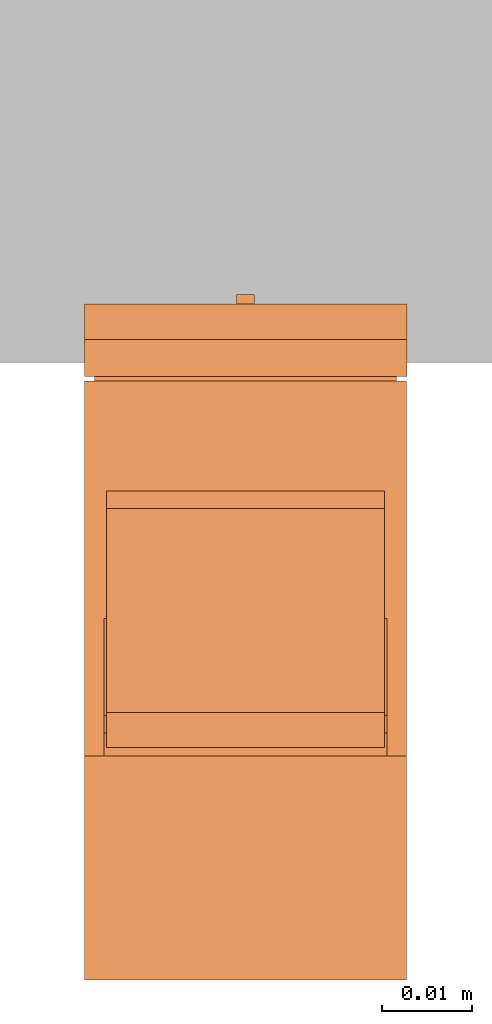
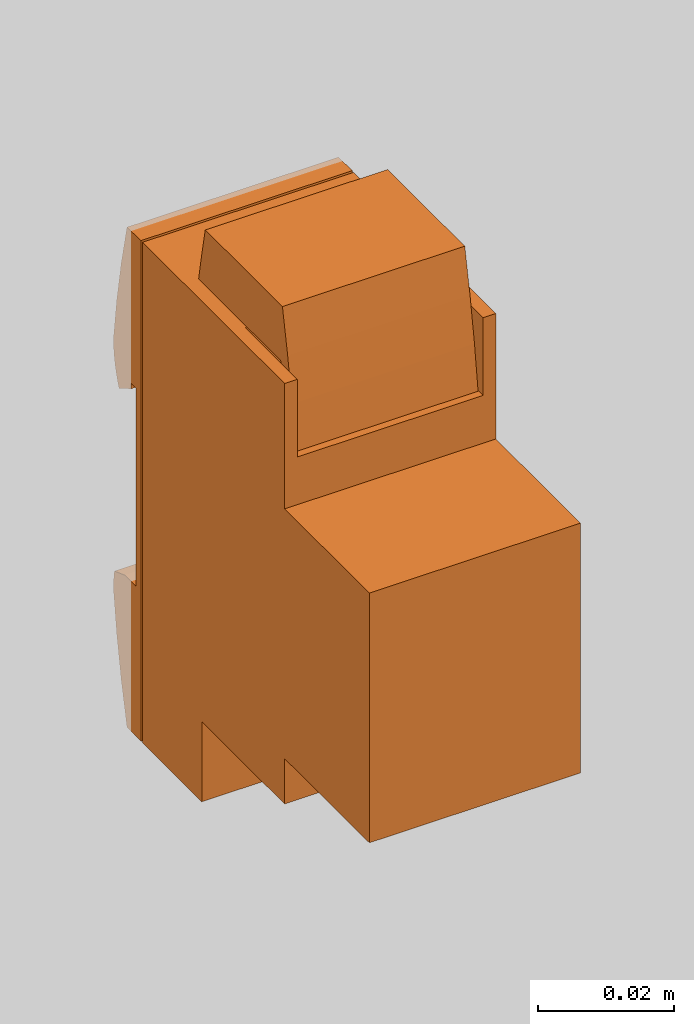
# One storey, part 2 of 2: 1 proxy.
"""IFC2X3 building model written with IfcOpenShell, lengths in metres."""

from ifc_helpers import new_model, entity, si_unit, converted_unit, derived_unit, direction, frame, frame_2d, origin, origin_2d_with_axis, place, context, subcontext, project, spatial, polyline, circle_curve, parameter, trimmed, segment, composite_curve, rectangle, circle, outline, extrude, source, transform, mapped, type_object, type_shapes, element, save


model = new_model("IFC2X3")

# Units and contexts
model_context = context("Model", 3, precision=1e-05, world=origin(), true_north=direction((6.12303176911189e-17, 1.0)))
body_context = subcontext(model_context, "Body", "Model", "MODEL_VIEW")
ifc_project = project(units=[si_unit("LENGTHUNIT", "METRE"), si_unit("AREAUNIT", "SQUARE_METRE"), si_unit("VOLUMEUNIT", "CUBIC_METRE"), converted_unit("PLANEANGLEUNIT", "DEGREE", entity("IfcRatioMeasure", 0.0174532925199433), si_unit("PLANEANGLEUNIT", "RADIAN"), dimensions=[0, 0, 0, 0, 0, 0, 0]), si_unit("MASSUNIT", "GRAM", prefix="KILO"), si_unit("TIMEUNIT", "SECOND"), si_unit("FREQUENCYUNIT", "HERTZ"), si_unit("THERMODYNAMICTEMPERATUREUNIT", "DEGREE_CELSIUS"), derived_unit("THERMALTRANSMITTANCEUNIT", [(si_unit("MASSUNIT", "GRAM", prefix="KILO"), 1), (si_unit("THERMODYNAMICTEMPERATUREUNIT", "KELVIN"), -1), (si_unit("TIMEUNIT", "SECOND"), -3)]), derived_unit("VOLUMETRICFLOWRATEUNIT", [(si_unit("LENGTHUNIT", "METRE"), 3), (si_unit("TIMEUNIT", "SECOND"), -1)]), si_unit("ELECTRICCURRENTUNIT", "AMPERE"), si_unit("ELECTRICVOLTAGEUNIT", "VOLT"), si_unit("POWERUNIT", "WATT"), si_unit("FORCEUNIT", "NEWTON", prefix="KILO"), si_unit("ILLUMINANCEUNIT", "LUX"), si_unit("LUMINOUSFLUXUNIT", "LUMEN"), si_unit("LUMINOUSINTENSITYUNIT", "CANDELA"), derived_unit("USERDEFINED", [(si_unit("MASSUNIT", "GRAM", prefix="KILO"), -1), (si_unit("LENGTHUNIT", "METRE"), -2), (si_unit("TIMEUNIT", "SECOND"), 3), (si_unit("LUMINOUSFLUXUNIT", "LUMEN"), 1)]), derived_unit("LINEARVELOCITYUNIT", [(si_unit("LENGTHUNIT", "METRE"), 1), (si_unit("TIMEUNIT", "SECOND"), -1)]), si_unit("PRESSUREUNIT", "PASCAL"), derived_unit("USERDEFINED", [(si_unit("LENGTHUNIT", "METRE"), -2), (si_unit("MASSUNIT", "GRAM", prefix="KILO"), 1), (si_unit("TIMEUNIT", "SECOND"), -2)])], contexts=[model_context])

# Site, building, storey
site_placement = place(None, origin())
site = spatial("IfcSite", under=ifc_project, at=site_placement, CompositionType="ELEMENT")
building_placement = place(site_placement, origin())
building = spatial("IfcBuilding", under=site, at=building_placement, CompositionType="ELEMENT")
storey_placement = place(building_placement, origin())
storey = spatial("IfcBuildingStorey", under=building, at=storey_placement, Name="Ebene 0", CompositionType="ELEMENT", Elevation=0.0)

# Proxy
building_element_proxy_type = type_object("IfcBuildingElementProxyType", PredefinedType="NOTDEFINED")
shared_shape = source(origin(), body_context, "Body", "SweptSolid", [
    extrude(rectangle(XDim=0.0877067597033699, YDim=0.0337171881892843, at=frame_2d((0.0, 6.76542155630955e-17), x_axis=(1.0, 0.0))), frame((0.0, -5.21424364943242e-06, 0.00149999999991786), z_axis=(0.0, 0.0, 1.0), x_axis=(0.0, -1.0, 0.0)), (0.0, 0.0, 1.0), 0.00250000000008027),
    extrude(outline(polyline([(-0.0043058254204434, -0.00315989961760552), (0.00882072072969625, -0.00315989961760552), (0.00885475551407708, 0.000740100382039403), (0.00527659597383583, 0.000740100382039403), (0.00527659597383583, 0.00244010017085836), (-0.00220582542044334, 0.00344010017085828), (-0.00379954108922811, 0.00344010017085828), (-0.00680582542044337, -0.000477765847556368), (-0.00680582542044337, -0.00164303636474464), (-0.0043058254204434, -0.00235989982914169), (-0.0043058254204434, -0.00315989961760552)])), frame((-0.00450269508344894, -0.021829279270313, -0.00315989961760737), z_axis=(1.0, 0.0, 0.0), x_axis=(0.0, -1.0, 0.0)), (0.0, 0.0, 1.0), 0.00900269508345517),
    extrude(circle(Radius=0.001, at=origin_2d_with_axis()), frame((-2.69508344888869e-06, -0.0200234538498851, -0.00768213377005103)), (0.0, 0.0, 1.0), 0.00768213377004916),
    extrude(outline(polyline([(-0.00706110679805229, -0.00330000000003701), (0.00708990984860641, -0.00330000000003701), (0.00714750717602578, 0.00330000000003703), (-0.0071763102265799, 0.00330000000003699), (-0.00706110679805229, -0.00330000000003701)])), frame((-0.0104999999999938, -0.0377975071760351, -0.0033000000000388), z_axis=(1.0, 0.0, 0.0), x_axis=(0.0, 1.0, 0.0)), (0.0, 0.0, 1.0), 0.0209999999999977),
    extrude(outline(composite_curve([segment(trimmed(circle_curve(frame_2d((-0.0221111921029964, -0.155663012752996), x_axis=(1.0, 0.0)), 0.16), [parameter(75.850687566287)], [parameter(84.0146643566966)], True, "PARAMETER"), True, "CONTINUOUS"), segment(trimmed(circle_curve(frame_2d((-0.00542736480497838, -0.0165352342016451), x_axis=(1.0, 0.0)), 0.0200000000000001), [parameter(89.999999999812)], [parameter(99.6900331453478)], True, "PARAMETER"), True, "CONTINUOUS"), segment(polyline([(-0.00879372299561325, 0.00317942107133271), (-0.00989875280170218, 0.000143376631281762)]), True, "CONTINUOUS"), segment(polyline([(-0.00989875280170218, 0.000143376631281762), (-0.00992736480497842, -0.00313523420171877)]), True, "CONTINUOUS"), segment(polyline([(-0.00992736480497842, -0.00313523420171877), (0.0170464525976306, -0.00313523420171877)]), True, "CONTINUOUS"), segment(polyline([(0.0170464525976307, -0.00313523420171877), (0.0170007528095759, -0.000517095097531858)]), True, "CONTINUOUS")], self_intersect=False)), frame((0.0105000000000039, -0.0279273648049843, -0.00313523420172056), z_axis=(1.0, 0.0, 0.0), x_axis=(0.0, -1.0, 0.0)), (0.0, 0.0, 1.0), 0.00744999999998763),
    extrude(outline(composite_curve([segment(trimmed(circle_curve(frame_2d((-0.0221111921029966, -0.155663012752995), x_axis=(1.0, 0.0)), 0.16), [parameter(75.8506875662867)], [parameter(84.0146643566962)], True, "PARAMETER"), True, "CONTINUOUS"), segment(trimmed(circle_curve(frame_2d((-0.00542736480497856, -0.016535234201645), x_axis=(1.0, 0.0)), 0.0200000000000001), [parameter(89.9999999998116)], [parameter(99.6900331453474)], True, "PARAMETER"), True, "CONTINUOUS"), segment(polyline([(-0.00879372299561343, 0.00317942107133273), (-0.00989875280170236, 0.000143376631281772)]), True, "CONTINUOUS"), segment(polyline([(-0.00989875280170236, 0.000143376631281772), (-0.0099273648049786, -0.00313523420171875)]), True, "CONTINUOUS"), segment(polyline([(-0.0099273648049786, -0.00313523420171875), (0.0170464525976304, -0.00313523420171875)]), True, "CONTINUOUS"), segment(polyline([(0.0170464525976305, -0.00313523420171875), (0.0170007528095757, -0.000517095097531838)]), True, "CONTINUOUS")], self_intersect=False)), frame((-0.0179499999999814, -0.0279273648049845, -0.00313523420172047), z_axis=(1.0, 0.0, 0.0), x_axis=(0.0, -1.0, 0.0)), (0.0, 0.0, 1.0), 0.00744999999998763),
    extrude(outline(polyline([(-0.00211624473774161, -0.00198520218472432), (0.00176512803190499, -0.00198520218472432), (0.00183392642755475, 0.00195625526230659), (-0.00148280972171813, 0.00201414910714203), (-0.00211624473774161, -0.00198520218472432)])), frame((-0.00480269508344881, -0.0469279114996043, -0.00179950574974599), z_axis=(1.0, 0.0, 0.0), x_axis=(0.0, -0.0174524064372911, 0.999847695156391)), (0.0, 0.0, 1.0), 0.00960000000000001),
    extrude(outline(polyline([(-0.0312738174026079, -0.000749999999962595), (0.0312999999999982, -0.000749999999962595), (0.0312738174026086, 0.000749999999962595), (-0.0312999999999989, 0.000749999999962595), (-0.0312738174026079, -0.000749999999962595)])), frame((-0.0179499999999814, -0.0137000000000071, 0.000749999999960853), z_axis=(1.0, 0.0, 0.0), x_axis=(0.0, 1.0, 0.0)), (0.0, 0.0, 1.0), 0.0359),
    extrude(outline(composite_curve([segment(trimmed(circle_curve(frame_2d((0.000186315113899719, 0.017838162813677), x_axis=(-0.947501881240194, -0.319750191628236)), 0.0200000000000001), [parameter(66.5760846945302)], [parameter(76.1282788842398)], True, "PARAMETER"), True, "CONTINUOUS"), segment(polyline([(0.00185155740972832, -0.00209239081877856), (0.000299012921520012, 0.00225617279684163)]), True, "CONTINUOUS"), segment(polyline([(0.000299012921520012, 0.00225617279684163), (-0.000671643149319465, 0.00192860884071545)]), True, "CONTINUOUS"), segment(polyline([(-0.000671643149319465, 0.00192860884071545), (-0.00147892718192889, -0.00209239081877856)]), True, "CONTINUOUS")], self_intersect=False)), frame((0.0129999999999934, 0.0166197101010987, -0.0034421185305304), z_axis=(1.0, 0.0, 0.0), x_axis=(0.0, 0.947501881240194, -0.319750191628236)), (0.0, 0.0, 1.0), 0.00495000000000036),
    extrude(outline(composite_curve([segment(trimmed(circle_curve(frame_2d((0.000186315113899647, 0.017838162813677), x_axis=(-0.947501881240192, -0.319750191628242)), 0.0200000000000001), [parameter(66.5760846945297)], [parameter(76.1282788842394)], True, "PARAMETER"), True, "CONTINUOUS"), segment(polyline([(0.00185155740972838, -0.00209239081877854), (0.000299012921520034, 0.00225617279684164)]), True, "CONTINUOUS"), segment(polyline([(0.000299012921520034, 0.00225617279684164), (-0.000671643149319442, 0.00192860884071545)]), True, "CONTINUOUS"), segment(polyline([(-0.000671643149319442, 0.00192860884071545), (-0.00147892718192884, -0.00209239081877856)]), True, "CONTINUOUS")], self_intersect=False)), frame((-0.0179499999999814, 0.0166197101010986, -0.00344211853053035), z_axis=(1.0, 0.0, 0.0), x_axis=(0.0, 0.947501881240192, -0.319750191628242)), (0.0, 0.0, 1.0), 0.00495000000000036),
    extrude(outline(composite_curve([segment(polyline([(9.73899078393611e-05, -0.0153873701208962), (0.0042161563200206, -0.0153873701208962)]), True, "CONTINUOUS"), segment(polyline([(0.0042161563200206, -0.0153873701208962), (0.00373750343430717, 0.012034635336042)]), True, "CONTINUOUS"), segment(polyline([(0.00373750343430717, 0.012034635336042), (-0.00377576050658934, 0.0117722663778383)]), True, "CONTINUOUS"), segment(trimmed(circle_curve(frame_2d((0.015721664747549, 0.00731688665672674), x_axis=(-0.0174524064373066, 0.999847695156391)), 0.0200000000000001), [parameter(76.1282788842394)], [parameter(90.000000000199)], True, "PARAMETER"), True, "CONTINUOUS"), segment(trimmed(circle_curve(frame_2d((0.154537080529411, 0.026426287465033), x_axis=(-0.0174524064373066, 0.999847695156391)), 0.16), [parameter(95.9853356433033)], [parameter(104.149312433712)], True, "PARAMETER"), True, "CONTINUOUS")], self_intersect=False)), frame((-0.0179499999999814, 0.0295413913763945, -0.00244696754172245), z_axis=(1.0, 0.0, 0.0), x_axis=(0.0, 0.0174524064373066, 0.999847695156391)), (0.0, 0.0, 1.0), 0.0359499999999876),
    extrude(outline(composite_curve([segment(trimmed(circle_curve(frame_2d((0.0437639322941393, 0.252147146800235), x_axis=(1.0, 0.0)), 0.265), [parameter(258.021351264932)], [parameter(263.216777092078)], True, "PARAMETER"), True, "CONTINUOUS"), segment(polyline([(0.0124639322941399, -0.0109978892540296), (0.01246393229414, -0.00856188095480952)]), True, "CONTINUOUS"), segment(trimmed(circle_curve(frame_2d((0.0437639322941385, 0.256597146800235), x_axis=(-1.0, 0.0)), 0.267), [parameter(80.2988826273655)], [parameter(83.2678237799807)], True, "PARAMETER"), False, "CONTINUOUS"), segment(polyline([(-0.00122786458828068, -0.00658480207409704), (-0.00122786458828237, 0.0175957532601113)]), True, "CONTINUOUS"), segment(trimmed(circle_curve(frame_2d((0.0447806993758774, -0.243278204892012), x_axis=(-1.0, 0.0)), 0.2649), [parameter(280.002012179108)], [parameter(282.208149894666)], True, "PARAMETER"), True, "CONTINUOUS"), segment(polyline([(-0.0112360677058602, 0.015631300158904), (-0.0112360677058602, -0.00708248113607989)]), True, "CONTINUOUS")], self_intersect=False)), frame((-0.0155055552147804, 0.0437639315311917, 0.0318504383826877), z_axis=(1.0, 0.0, 0.0), x_axis=(0.0, -1.0, 0.0)), (0.0, 0.0, 1.0), 0.031005555214787),
    extrude(outline(polyline([(-0.00630661895219968, -0.00520657357205292), (-0.0037282913969504, -0.00520657357205292), (-0.00174523279425085, -0.00360072437869802), (0.00904338104780031, -0.0035065735720529), (0.00904338104780031, 0.00876022254742837), (-0.00630661895219968, 0.00876022254742837), (-0.00630661895219968, -0.00520657357205292)])), frame((0.0157999999999935, 0.0362315735720441, 0.0375133810764088), z_axis=(1.0, 0.0, 0.0), x_axis=(0.0, 0.0, -1.0)), (0.0, 0.0, 1.0), 0.00214999999999999),
    extrude(outline(polyline([(-0.00630661895219968, -0.00520657357205292), (-0.00372829139695041, -0.00520657357205292), (-0.00174523279425086, -0.00360072437869802), (0.00904338104780031, -0.0035065735720529), (0.00904338104780031, 0.00876022254742837), (-0.00630661895219968, 0.00876022254742837), (-0.00630661895219968, -0.00520657357205292)])), frame((-0.017949999999981, 0.0362315735720441, 0.0375133810764088), z_axis=(1.0, 0.0, 0.0), x_axis=(0.0, 0.0, -1.0)), (0.0, 0.0, 1.0), 0.00214999999999999),
    extrude(outline(polyline([(-0.0177221827548344, -0.0335528366937999), (0.0271778172451656, -0.0335528366937999), (0.0271778172451656, -0.00860283669379978), (0.0353278172451656, -0.00860283669379975), (0.0353278172451655, 0.0157971633062003), (0.0497278172451655, 0.0157971633062003), (0.0497278172451654, 0.0332471633062003), (-0.0402639788743159, 0.0332471633062), (-0.0402639788743158, 0.00674716330620002), (-0.0279971827548345, 0.00674716330620006), (-0.0279030319481893, -0.00404145053585112), (-0.0262971827548344, -0.00602450913855065), (-0.0262971827548344, -0.00860283669379993), (-0.0177221827548345, -0.00860283669379991), (-0.0177221827548344, -0.0335528366937999)])), frame((-0.017949999999981, 0.00472781724515668, 0.0352171633348086), z_axis=(1.0, 0.0, 0.0), x_axis=(0.0, -1.0, 0.0)), (0.0, 0.0, 1.0), 0.0359),
])
type_shapes(building_element_proxy_type, [shared_shape])
proxy_placement = place(storey_placement, frame((-7.3192018927039, -2.38240134987377, 1.34937952893394), z_axis=(0.0, -1.0, 0.0), x_axis=(1.0, 0.0, 0.0)))
element("IfcBuildingElementProxy", 1, at=proxy_placement, inside=storey, type_object=building_element_proxy_type, Name="216700:IP", context=body_context, shape_type="MappedRepresentation", body=[
    mapped(shared_shape, transform((0.0, 0.0, 0.0), scale=1.0)),
])

save(model, "model.ifc")
